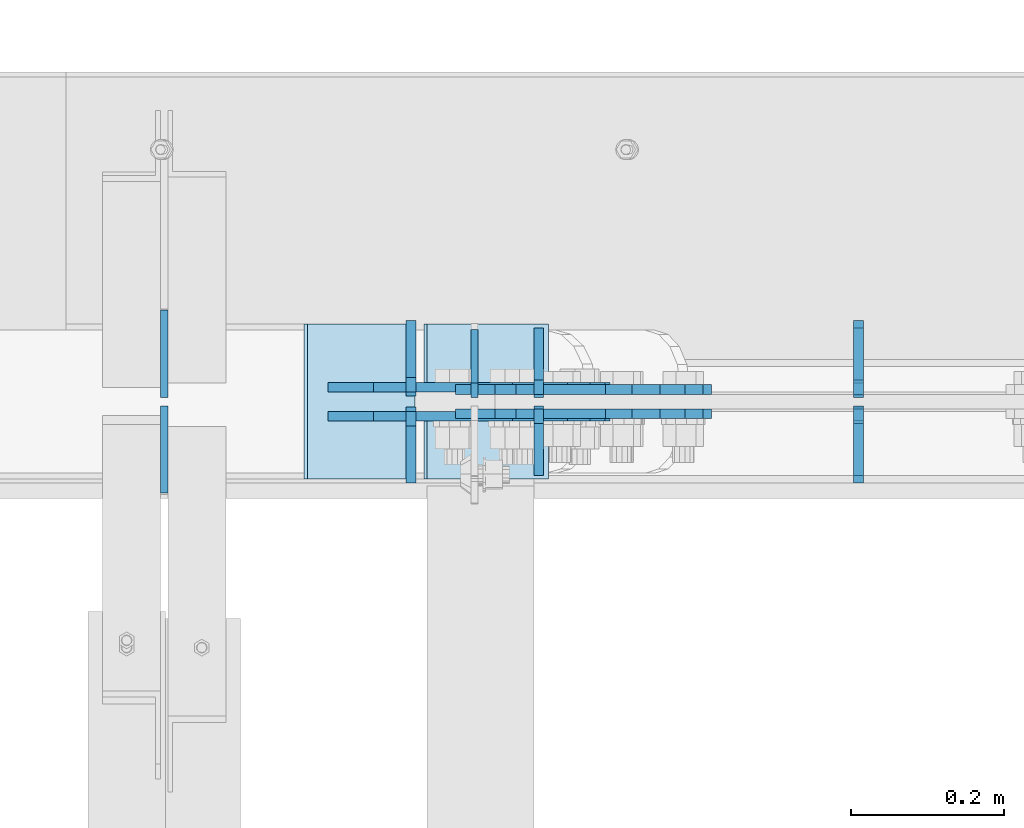
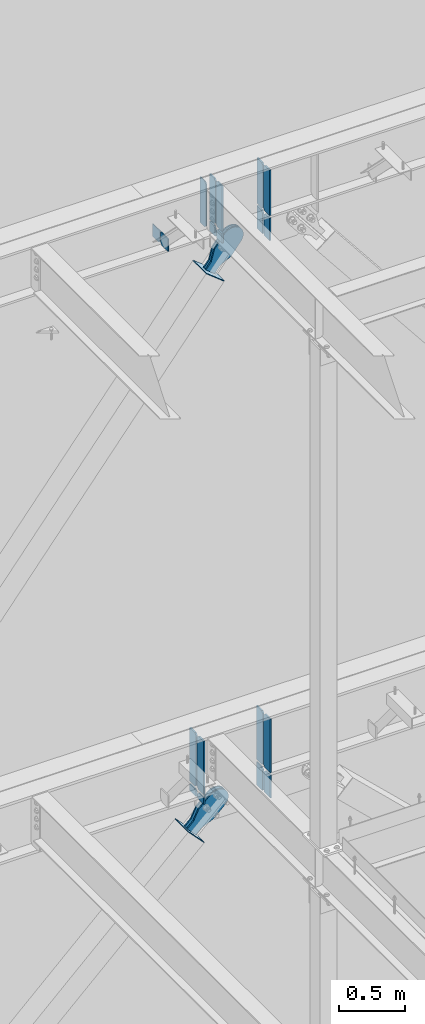
# One storey, part 1100 of 1179: 25 plates, 8 elements without a shape of their own.
"""IFC2X3 building model written with IfcOpenShell, lengths in millimetres."""

from ifc_helpers import new_model, si_unit, frame, origin_with_axes, place, context, subcontext, project, spatial, faceted_brep, material, type_object, element, aggregate, save


model = new_model("IFC2X3")

# Units and contexts
model_context = context("Model", 3, precision=1e-05, world=origin_with_axes())
body_context = subcontext(model_context, "Body", "Model", "MODEL_VIEW")
ifc_project = project(units=[si_unit("LENGTHUNIT", "METRE", prefix="MILLI"), si_unit("AREAUNIT", "SQUARE_METRE"), si_unit("VOLUMEUNIT", "CUBIC_METRE"), si_unit("MASSUNIT", "GRAM", prefix="KILO"), si_unit("TIMEUNIT", "SECOND"), si_unit("PLANEANGLEUNIT", "RADIAN"), si_unit("SOLIDANGLEUNIT", "STERADIAN"), si_unit("THERMODYNAMICTEMPERATUREUNIT", "DEGREE_CELSIUS"), si_unit("LUMINOUSINTENSITYUNIT", "LUMEN")], contexts=[model_context])

# Site, building, storey
site_placement = place(None, origin_with_axes())
site = spatial("IfcSite", under=ifc_project, at=site_placement, CompositionType="ELEMENT")
building_placement = place(site_placement, origin_with_axes())
building = spatial("IfcBuilding", under=site, at=building_placement, Name="Undefined", CompositionType="ELEMENT")
storey_placement = place(building_placement, origin_with_axes())
storey = spatial("IfcBuildingStorey", under=building, at=storey_placement, Name="Undefined", CompositionType="ELEMENT", Elevation=0.0)

# Assembly, plate
assembly_1_placement = place(storey_placement, origin_with_axes())
assembly_1 = element("IfcElementAssembly", 1, at=assembly_1_placement, inside=storey, Name="BEAM", AssemblyPlace="NOTDEFINED", PredefinedType="RIGID_FRAME")
ifc_material_1 = material(Name="STEEL/A36")
plate_type_1 = type_object("IfcPlateType", PredefinedType="NOTDEFINED")
plate_1_placement = place(assembly_1_placement, frame((11866.5620000839, 41204.35625, 12673.0125), z_axis=(0.0, 0.0, 1.0), x_axis=(0.0, 1.0, 0.0)))
plate_1 = element("IfcPlate", 2, at=plate_1_placement, type_object=plate_type_1, material=ifc_material_1, Name="PLATE", context=body_context, shape_type="Brep", body=[
    faceted_brep([(0.0, -4.76250000000073, 19.0499992370605), (0.0, -4.76249999999709, 406.400000762939), (0.0, 4.76249999999709, 406.400000762939), (0.0, 4.76250000000073, 19.0499992370605), (19.0499992370605, -4.76249999999709, 425.45), (19.0499992370605, 4.76249999999709, 425.45), (88.9000015258789, -4.76250000000073, 425.450012207031), (88.9000015258789, 4.76250000000073, 425.450012207031), (88.8999999999996, -4.76250000000005, 0.0), (88.8999999999996, 4.76250000000005, 0.0), (19.0499992370605, -4.76250000000073, 0.0), (19.0499992370605, 4.76250000000073, 0.0)], [[[0, 1, 2, 3]], [[1, 4, 5, 2]], [[4, 6, 7, 5]], [[6, 8, 9, 7]], [[8, 10, 11, 9]], [[10, 0, 3, 11]], [[5, 7, 9, 11, 3, 2]], [[10, 8, 6, 4, 1, 0]]]),
])

# Assembly, plates
assembly_2_placement = place(storey_placement, origin_with_axes())
assembly_2 = element("IfcElementAssembly", 3, at=assembly_2_placement, inside=storey, Name="BEAM", AssemblyPlace="NOTDEFINED", PredefinedType="RIGID_FRAME")
ifc_material_2 = material(Name="STEEL/A572-GR.50")
plate_type_2 = type_object("IfcPlateType", PredefinedType="NOTDEFINED")
plate_2_placement = place(assembly_2_placement, frame((12369.8, 41205.94375, 7488.2375), z_axis=(0.0, 1.0, 0.0), x_axis=(0.0, 0.0, 1.0)))
plate_2 = element("IfcPlate", 4, at=plate_2_placement, type_object=plate_type_2, material=ifc_material_2, Name="PLATE", context=body_context, shape_type="Brep", body=[
    faceted_brep([(0.0, -6.34999999998763, 17.4624996185248), (0.0, -6.35000000000036, 99.21875), (0.0, 6.35000000000036, 99.21875), (0.0, 6.35000000000582, 17.4624996185175), (501.65, -6.35000000000036, 99.21875), (501.65, 6.35000000000036, 99.21875), (501.65, -6.35000000000036, 17.4624996185303), (501.65, 6.35000000000036, 17.4624996185303), (484.187500381469, -6.35000000000036, 0.0), (484.187500381469, 6.35000000000036, 0.0), (17.4624996185303, -6.34999999999309, 1.81898940354586e-12), (17.4624996185303, 6.34999999999854, -1.81898940354586e-12)], [[[0, 1, 2, 3]], [[1, 4, 5, 2]], [[4, 6, 7, 5]], [[6, 8, 9, 7]], [[8, 10, 11, 9]], [[10, 0, 3, 11]], [[5, 7, 9, 11, 3, 2]], [[10, 8, 6, 4, 1, 0]]]),
])
plate_3_placement = place(assembly_2_placement, frame((12369.8, 41191.65625, 7488.2375), z_axis=(0.0, -1.0, 0.0), x_axis=(0.0, 0.0, 1.0)))
plate_3 = element("IfcPlate", 5, at=plate_3_placement, type_object=plate_type_2, material=ifc_material_2, Name="PLATE", context=body_context, shape_type="Brep", body=[
    faceted_brep([(0.0, -6.34999999998763, 17.4624996185248), (0.0, -6.35000000000036, 99.21875), (0.0, 6.35000000000036, 99.21875), (0.0, 6.35000000000582, 17.4624996185175), (501.65, -6.35000000000036, 99.21875), (501.65, 6.35000000000036, 99.21875), (501.65, -6.35000000000036, 17.4624996185303), (501.65, 6.35000000000036, 17.4624996185303), (484.187500381469, -6.35000000000036, 0.0), (484.187500381469, 6.35000000000036, 0.0), (17.4624996185303, -6.34999999999309, 1.81898940354586e-12), (17.4624996185303, 6.34999999999854, -1.81898940354586e-12)], [[[0, 1, 2, 3]], [[1, 4, 5, 2]], [[4, 6, 7, 5]], [[6, 8, 9, 7]], [[8, 10, 11, 9]], [[10, 0, 3, 11]], [[5, 7, 9, 11, 3, 2]], [[10, 8, 6, 4, 1, 0]]]),
])
plate_4_placement = place(assembly_2_placement, frame((11783.4171875, 41205.94375, 7489.825), z_axis=(0.0, 1.0, 0.0), x_axis=(0.0, 0.0, 1.0)))
plate_4 = element("IfcPlate", 6, at=plate_4_placement, type_object=plate_type_2, material=ifc_material_2, Name="PLATE", context=body_context, shape_type="Brep", body=[
    faceted_brep([(0.0, -6.35000000000036, 19.0499999999993), (0.0, -6.35000000000036, 99.21875), (0.0, 6.35000000000036, 99.21875), (0.0, 6.35000000000036, 19.0499999999993), (498.475, -6.35000000000036, 99.21875), (498.475, 6.35000000000036, 99.21875), (498.475006103516, -6.35000000000036, 19.0499992370605), (498.475006103516, 6.35000000000036, 19.0499992370605), (479.425006866455, -6.35000000000036, 0.0), (479.425006866455, 6.35000000000036, 0.0), (19.0500000000002, -6.35000000000036, 0.0), (19.0500000000002, 6.35000000000036, 0.0)], [[[0, 1, 2, 3]], [[1, 4, 5, 2]], [[4, 6, 7, 5]], [[6, 8, 9, 7]], [[8, 10, 11, 9]], [[3, 11, 10, 0]], [[5, 7, 9, 11, 3, 2]], [[10, 8, 6, 4, 1, 0]]]),
])
plate_5_placement = place(assembly_2_placement, frame((11783.4171875, 41191.65625, 7489.825), z_axis=(0.0, -1.0, 0.0), x_axis=(0.0, 0.0, 1.0)))
plate_5 = element("IfcPlate", 7, at=plate_5_placement, type_object=plate_type_2, material=ifc_material_2, Name="PLATE", context=body_context, shape_type="Brep", body=[
    faceted_brep([(0.0, -6.35000000000036, 19.0499999999993), (0.0, -6.35000000000036, 99.21875), (0.0, 6.35000000000036, 99.21875), (0.0, 6.35000000000036, 19.0499999999993), (498.475, -6.35000000000036, 99.21875), (498.475, 6.35000000000036, 99.21875), (498.475006103516, -6.35000000000036, 19.0499992370605), (498.475006103516, 6.35000000000036, 19.0499992370605), (479.425006866455, -6.35000000000036, 0.0), (479.425006866455, 6.35000000000036, 0.0), (19.0500000000002, -6.35000000000036, 0.0), (19.0500000000002, 6.35000000000036, 0.0)], [[[0, 1, 2, 3]], [[1, 4, 5, 2]], [[4, 6, 7, 5]], [[6, 8, 9, 7]], [[8, 10, 11, 9]], [[3, 11, 10, 0]], [[5, 7, 9, 11, 3, 2]], [[10, 8, 6, 4, 1, 0]]]),
])

# Assembly, plate
assembly_3_placement = place(storey_placement, origin_with_axes())
assembly_3 = element("IfcElementAssembly", 8, at=assembly_3_placement, inside=storey, Name="Plate", AssemblyPlace="NOTDEFINED", PredefinedType="RIGID_FRAME")
plate_type_3 = type_object("IfcPlateType", PredefinedType="NOTDEFINED")
plate_6_placement = place(assembly_3_placement, frame((11961.3934668224, 41097.2, 12208.4235733512), z_axis=(-0.782937860640372, 0.0, 0.62209991671425), x_axis=(0.0, 1.0, 0.0)))
plate_6 = element("IfcPlate", 9, at=plate_6_placement, type_object=plate_type_3, material=ifc_material_1, Name="Plate", context=body_context, shape_type="Brep", body=[
    faceted_brep([(0.0, -3.17500000000109, 0.0), (0.0, -3.17500000000291, 203.200000000368), (0.0, 3.17499999998836, 203.200000000361), (0.0, 3.17500000000109, 7.27595761418343e-12), (203.199999999997, -3.17500000000291, 203.200000000368), (203.199999999997, 3.17499999998836, 203.200000000361), (203.199999999997, -3.17499999999927, 3.63797880709171e-12), (203.199999999997, 3.17499999999382, -3.63797880709171e-12)], [[[0, 1, 2, 3]], [[1, 4, 5, 2]], [[4, 6, 7, 5]], [[6, 0, 3, 7]], [[5, 7, 3, 2]], [[6, 4, 1, 0]]]),
])
aggregate(assembly_3, [plate_6])

assembly_4_placement = place(storey_placement, origin_with_axes())
assembly_4 = element("IfcElementAssembly", 10, at=assembly_4_placement, inside=storey, Name="Plate", AssemblyPlace="NOTDEFINED", PredefinedType="RIGID_FRAME")
plate_7_placement = place(assembly_4_placement, frame((11786.1245523954, 41097.2, 7040.16901299028), z_axis=(-0.691222646058185, 0.0, 0.722641857060828), x_axis=(0.0, 1.0, 0.0)))
plate_7 = element("IfcPlate", 11, at=plate_7_placement, type_object=plate_type_3, material=ifc_material_1, Name="Plate", context=body_context, shape_type="Brep", body=[
    faceted_brep([(0.0, -3.17500000000109, 0.0), (0.0, -3.17500000000291, 203.200000000368), (0.0, 3.17499999998836, 203.200000000361), (0.0, 3.17500000000109, 7.27595761418343e-12), (203.199999999997, -3.17500000000291, 203.200000000368), (203.199999999997, 3.17499999998836, 203.200000000361), (203.199999999997, -3.17499999999927, 3.63797880709171e-12), (203.199999999997, 3.17499999999382, -3.63797880709171e-12)], [[[0, 1, 2, 3]], [[1, 4, 5, 2]], [[4, 6, 7, 5]], [[6, 0, 3, 7]], [[5, 7, 3, 2]], [[6, 4, 1, 0]]]),
])
aggregate(assembly_4, [plate_7])

# Plate
plate_type_4 = type_object("IfcPlateType", PredefinedType="NOTDEFINED")
plate_8_placement = place(assembly_1_placement, frame((12369.7999987844, 41204.35625, 12673.0125), z_axis=(0.0, 1.0, 0.0), x_axis=(0.0, 0.0, 1.0)))
plate_8 = element("IfcPlate", 12, at=plate_8_placement, type_object=plate_type_4, material=ifc_material_2, Name="PLATE", context=body_context, shape_type="Brep", body=[
    faceted_brep([(0.0, -6.34999999998763, 17.4624996185248), (0.0, -6.35000000000036, 91.28125), (0.0, 6.35000000000036, 91.28125), (0.0, 6.35000000000582, 17.4624996185175), (425.450000000001, -6.35000000000036, 91.28125), (425.450000000001, 6.35000000000036, 91.28125), (425.450000000001, -6.35000000000036, 17.4624996185303), (425.450000000001, 6.35000000000036, 17.4624996185303), (407.98750038147, -6.35000000000036, 0.0), (407.98750038147, 6.35000000000036, 0.0), (17.4624996185303, -6.34999999999309, 1.81898940354586e-12), (17.4624996185303, 6.34999999999854, -1.81898940354586e-12)], [[[0, 1, 2, 3]], [[1, 4, 5, 2]], [[4, 6, 7, 5]], [[6, 8, 9, 7]], [[8, 10, 11, 9]], [[10, 0, 3, 11]], [[5, 7, 9, 11, 3, 2]], [[10, 8, 6, 4, 1, 0]]]),
])

plate_9_placement = place(assembly_1_placement, frame((12369.7999987844, 41193.24375, 12673.0125), z_axis=(0.0, -1.0, 0.0), x_axis=(0.0, 0.0, 1.0)))
plate_9 = element("IfcPlate", 13, at=plate_9_placement, type_object=plate_type_4, material=ifc_material_2, Name="PLATE", context=body_context, shape_type="Brep", body=[
    faceted_brep([(0.0, -6.34999999998763, 17.4624996185248), (0.0, -6.35000000000036, 91.28125), (0.0, 6.35000000000036, 91.28125), (0.0, 6.35000000000582, 17.4624996185175), (425.450000000001, -6.35000000000036, 91.28125), (425.450000000001, 6.35000000000036, 91.28125), (425.450000000001, -6.35000000000036, 17.4624996185303), (425.450000000001, 6.35000000000036, 17.4624996185303), (407.98750038147, -6.35000000000036, 0.0), (407.98750038147, 6.35000000000036, 0.0), (17.4624996185303, -6.34999999999309, 1.81898940354586e-12), (17.4624996185303, 6.34999999999854, -1.81898940354586e-12)], [[[0, 1, 2, 3]], [[1, 4, 5, 2]], [[4, 6, 7, 5]], [[6, 8, 9, 7]], [[8, 10, 11, 9]], [[10, 0, 3, 11]], [[5, 7, 9, 11, 3, 2]], [[10, 8, 6, 4, 1, 0]]]),
])

plate_type_5 = type_object("IfcPlateType", PredefinedType="NOTDEFINED")
plate_10_placement = place(assembly_1_placement, frame((11950.7, 41208.325, 12652.375), z_axis=(0.0, 1.0, 0.0), x_axis=(0.0, 0.0, -1.0)))
plate_10 = element("IfcPlate", 14, at=plate_10_placement, type_object=plate_type_5, material=ifc_material_2, Name="PLATE", context=body_context, shape_type="Brep", body=[
    faceted_brep([(0.0, 6.35000000000036, 19.0499999999993), (19.0500000000002, 6.35000000000036, 0.0), (19.0500000000002, -6.35000000000036, 0.0), (0.0, -6.35000000000036, 19.0499999999993), (0.0, -6.35000000000036, 87.3125), (0.0, 6.35000000000036, 87.3125), (88.7851254133348, -6.35000000000036, 87.3125), (88.7851254133348, 6.35000000000036, 87.3125), (88.7851254133348, -6.35000000000036, 0.0), (88.7851254133348, 6.35000000000036, 0.0)], [[[0, 1, 2, 3]], [[4, 5, 0, 3]], [[4, 6, 7, 5]], [[6, 8, 9, 7]], [[9, 8, 2, 1]], [[5, 7, 9, 1, 0]], [[8, 6, 4, 3, 2]]]),
])

plate_11_placement = place(assembly_1_placement, frame((11950.7, 41189.275, 12652.375), z_axis=(0.0, -1.0, 0.0), x_axis=(0.0, 0.0, -1.0)))
plate_11 = element("IfcPlate", 15, at=plate_11_placement, type_object=plate_type_5, material=ifc_material_2, Name="PLATE", context=body_context, shape_type="Brep", body=[
    faceted_brep([(0.0, 6.35000000000036, 19.0499999999993), (19.0500000000002, 6.35000000000036, 0.0), (19.0500000000002, -6.35000000000036, 0.0), (0.0, -6.35000000000036, 19.0499999999993), (0.0, -6.35000000000036, 87.3125), (0.0, 6.35000000000036, 87.3125), (88.7851254133348, -6.35000000000036, 87.3125), (88.7851254133348, 6.35000000000036, 87.3125), (88.7851254133348, -6.35000000000036, 0.0), (88.7851254133348, 6.35000000000036, 0.0)], [[[0, 1, 2, 3]], [[4, 5, 0, 3]], [[4, 6, 7, 5]], [[6, 8, 9, 7]], [[9, 8, 2, 1]], [[5, 7, 9, 1, 0]], [[8, 6, 4, 3, 2]]]),
])

plate_12_placement = place(assembly_1_placement, frame((12369.8, 41208.325, 12440.8523319191), z_axis=(0.0, 1.0, 0.0), x_axis=(0.0, 0.0, 1.0)))
plate_12 = element("IfcPlate", 16, at=plate_12_placement, type_object=plate_type_5, material=ifc_material_2, Name="PLATE", context=body_context, shape_type="Brep", body=[
    faceted_brep([(211.522668080917, -6.35000000000036, 19.0500000000029), (192.472668080918, -6.35000000000036, 0.0), (192.472668080918, 6.35000000000036, 0.0), (211.522668080917, 6.35000000000036, 19.0500000000029), (0.0, -6.34999999999854, 0.0), (0.0, -6.35000000000036, 87.3125), (0.0, 6.35000000000036, 87.3125), (0.0, 6.34999999999854, 0.0), (211.522668080917, -6.35000000000036, 87.3125), (211.522668080917, 6.35000000000036, 87.3125)], [[[0, 1, 2, 3]], [[4, 5, 6, 7]], [[5, 8, 9, 6]], [[9, 8, 0, 3]], [[4, 7, 2, 1]], [[7, 6, 9, 3, 2]], [[8, 5, 4, 1, 0]]]),
])

plate_13_placement = place(assembly_1_placement, frame((12369.8, 41189.275, 12440.8523319191), z_axis=(0.0, -1.0, 0.0), x_axis=(0.0, 0.0, 1.0)))
plate_13 = element("IfcPlate", 17, at=plate_13_placement, type_object=plate_type_5, material=ifc_material_2, Name="PLATE", context=body_context, shape_type="Brep", body=[
    faceted_brep([(211.522668080917, -6.35000000000036, 19.0500000000029), (192.472668080918, -6.35000000000036, 0.0), (192.472668080918, 6.35000000000036, 0.0), (211.522668080917, 6.35000000000036, 19.0500000000029), (0.0, -6.34999999999854, 0.0), (0.0, -6.35000000000036, 87.3125), (0.0, 6.35000000000036, 87.3125), (0.0, 6.34999999999854, 0.0), (211.522668080917, -6.35000000000036, 87.3125), (211.522668080917, 6.35000000000036, 87.3125)], [[[0, 1, 2, 3]], [[4, 5, 6, 7]], [[5, 8, 9, 6]], [[9, 8, 0, 3]], [[4, 7, 2, 1]], [[7, 6, 9, 3, 2]], [[8, 5, 4, 1, 0]]]),
])

plate_type_6 = type_object("IfcPlateType", PredefinedType="NOTDEFINED")
plate_14_placement = place(assembly_1_placement, frame((11950.7, 41104.34375, 12673.0125), z_axis=(0.0, 0.0, 1.0), x_axis=(0.0, 1.0, 0.0)))
plate_14 = element("IfcPlate", 18, at=plate_14_placement, type_object=plate_type_6, material=ifc_material_2, Name="PLATE", context=body_context, shape_type="Brep", body=[
    faceted_brep([(0.0, -6.34999999999854, 0.0), (0.0, -6.34999999999991, 425.450012207031), (0.0, 6.34999999999991, 425.450012207031), (0.0, 6.34999999999854, 0.0), (69.8500022888184, -6.34999999999991, 425.450012207031), (69.8500022888184, 6.34999999999991, 425.450012207031), (88.9000015258789, -6.34999999999991, 406.400012969971), (88.9000015258789, 6.34999999999991, 406.400012969971), (88.9000015258789, -6.34999999999991, 19.0499992370605), (88.9000015258789, 6.34999999999991, 19.0499992370605), (69.849999425729, -6.34999999999854, 0.0), (69.849999425729, 6.34999999999854, 0.0)], [[[0, 1, 2, 3]], [[1, 4, 5, 2]], [[4, 6, 7, 5]], [[6, 8, 9, 7]], [[8, 10, 11, 9]], [[10, 0, 3, 11]], [[5, 7, 9, 11, 3, 2]], [[10, 8, 6, 4, 1, 0]]]),
])

plate_15_placement = place(assembly_1_placement, frame((11950.7, 41204.35625, 12673.0125), z_axis=(0.0, 0.0, 1.0), x_axis=(0.0, 1.0, 0.0)))
plate_15 = element("IfcPlate", 19, at=plate_15_placement, type_object=plate_type_6, material=ifc_material_2, Name="PLATE", context=body_context, shape_type="Brep", body=[
    faceted_brep([(0.0, -6.35000000000036, 19.0499999999993), (0.0, -6.34999999999991, 406.400012969971), (0.0, 6.34999999999991, 406.400012969971), (0.0, 6.35000000000036, 19.0499999999993), (19.0499992370605, -6.34999999999991, 425.450012207031), (19.0499992370605, 6.34999999999991, 425.450012207031), (88.9000015258789, -6.34999999999991, 425.450012207031), (88.9000015258789, 6.34999999999991, 425.450012207031), (88.9000015258789, -6.34999999999991, 0.0), (88.9000015258789, 6.34999999999991, 0.0), (19.0500000000002, -6.35000000000036, 0.0), (19.0500000000002, 6.35000000000036, 0.0)], [[[0, 1, 2, 3]], [[1, 4, 5, 2]], [[4, 6, 7, 5]], [[6, 8, 9, 7]], [[8, 10, 11, 9]], [[3, 11, 10, 0]], [[5, 7, 9, 11, 3, 2]], [[10, 8, 6, 4, 1, 0]]]),
])

plate_type_7 = type_object("IfcPlateType", PredefinedType="NOTDEFINED")
plate_16_placement = place(assembly_2_placement, frame((11783.4171875, 41211.5, 7464.42500002202), z_axis=(0.0, 1.0, 0.0), x_axis=(0.0, 0.0, -1.0)))
plate_16 = element("IfcPlate", 20, at=plate_16_placement, type_object=plate_type_7, material=ifc_material_2, Name="PLATE", context=body_context, shape_type="Brep", body=[
    faceted_brep([(0.0, 6.35000000000036, 19.0499999999993), (19.0500000000002, 6.35000000000036, 0.0), (19.0500000000002, -6.35000000000036, 0.0), (0.0, -6.35000000000036, 19.0499999999993), (0.0, -6.35000000000036, 93.6625000000058), (0.0, 6.35000000000036, 93.6625000000058), (63.5020087381745, -6.35000000000036, 93.6625000000058), (63.5020087381745, 6.35000000000036, 93.6625000000058), (63.5020087381745, -6.35000000000036, 0.0), (63.5020087381745, 6.35000000000036, 0.0)], [[[0, 1, 2, 3]], [[4, 5, 0, 3]], [[4, 6, 7, 5]], [[6, 8, 9, 7]], [[9, 8, 2, 1]], [[5, 7, 9, 1, 0]], [[8, 6, 4, 3, 2]]]),
])

plate_17_placement = place(assembly_2_placement, frame((11783.4171875, 41186.1, 7464.42500002202), z_axis=(0.0, -1.0, 0.0), x_axis=(0.0, 0.0, -1.0)))
plate_17 = element("IfcPlate", 21, at=plate_17_placement, type_object=plate_type_7, material=ifc_material_2, Name="PLATE", context=body_context, shape_type="Brep", body=[
    faceted_brep([(0.0, 6.35000000000036, 19.0499999999993), (19.0500000000002, 6.35000000000036, 0.0), (19.0500000000002, -6.35000000000036, 0.0), (0.0, -6.35000000000036, 19.0499999999993), (0.0, -6.35000000000036, 93.6625000000058), (0.0, 6.35000000000036, 93.6625000000058), (63.5020087381745, -6.35000000000036, 93.6625000000058), (63.5020087381745, 6.35000000000036, 93.6625000000058), (63.5020087381745, -6.35000000000036, 0.0), (63.5020087381745, 6.35000000000036, 0.0)], [[[0, 1, 2, 3]], [[4, 5, 0, 3]], [[4, 6, 7, 5]], [[6, 8, 9, 7]], [[9, 8, 2, 1]], [[5, 7, 9, 1, 0]], [[8, 6, 4, 3, 2]]]),
])

plate_type_8 = type_object("IfcPlateType", PredefinedType="NOTDEFINED")
plate_18_placement = place(assembly_2_placement, frame((12369.8, 41211.5, 7464.425), z_axis=(0.0, 1.0, 0.0), x_axis=(0.0, 0.0, -1.0)))
plate_18 = element("IfcPlate", 22, at=plate_18_placement, type_object=plate_type_8, material=ifc_material_2, Name="PLATE", context=body_context, shape_type="Brep", body=[
    faceted_brep([(0.0, 6.35000000000036, 19.0499999999993), (19.0500000000002, 6.35000000000036, 0.0), (19.0500000000002, -6.35000000000036, 0.0), (0.0, -6.35000000000036, 19.0499999999993), (0.0, -6.35000000000036, 93.6625000000058), (0.0, 6.35000000000036, 93.6625000000058), (210.181102062119, -6.35000000000036, 93.6625000000058), (210.181102062119, 6.35000000000036, 93.6625000000058), (210.181102062119, -6.35000000000036, 0.0), (210.181102062119, 6.35000000000036, 0.0)], [[[0, 1, 2, 3]], [[4, 5, 0, 3]], [[4, 6, 7, 5]], [[6, 8, 9, 7]], [[9, 8, 2, 1]], [[5, 7, 9, 1, 0]], [[8, 6, 4, 3, 2]]]),
])

plate_19_placement = place(assembly_2_placement, frame((12369.8, 41186.1, 7464.425), z_axis=(0.0, -1.0, 0.0), x_axis=(0.0, 0.0, -1.0)))
plate_19 = element("IfcPlate", 23, at=plate_19_placement, type_object=plate_type_8, material=ifc_material_2, Name="PLATE", context=body_context, shape_type="Brep", body=[
    faceted_brep([(0.0, 6.35000000000036, 19.0499999999993), (19.0500000000002, 6.35000000000036, 0.0), (19.0500000000002, -6.35000000000036, 0.0), (0.0, -6.35000000000036, 19.0499999999993), (0.0, -6.35000000000036, 93.6625000000058), (0.0, 6.35000000000036, 93.6625000000058), (210.181102062119, -6.35000000000036, 93.6625000000058), (210.181102062119, 6.35000000000036, 93.6625000000058), (210.181102062119, -6.35000000000036, 0.0), (210.181102062119, 6.35000000000036, 0.0)], [[[0, 1, 2, 3]], [[4, 5, 0, 3]], [[4, 6, 7, 5]], [[6, 8, 9, 7]], [[9, 8, 2, 1]], [[5, 7, 9, 1, 0]], [[8, 6, 4, 3, 2]]]),
])

aggregate(assembly_2, [plate_2, plate_3, plate_16, plate_17, plate_4, plate_5, plate_18, plate_19])

# Assembly, plate
assembly_5_placement = place(storey_placement, origin_with_axes())
assembly_5 = element("IfcElementAssembly", 24, at=assembly_5_placement, inside=storey, AssemblyPlace="NOTDEFINED", PredefinedType="RIGID_FRAME")
plate_type_9 = type_object("IfcPlateType", PredefinedType="NOTDEFINED")
plate_20_placement = place(assembly_5_placement, frame((11917.9044352925, 41214.675, 12238.9234688004), z_axis=(-0.782937860640372, 0.0, 0.62209991671425), x_axis=(0.622099916714251, 0.0, 0.782937860640372)))
plate_20 = element("IfcPlate", 25, at=plate_20_placement, type_object=plate_type_9, material=ifc_material_1, context=body_context, shape_type="Brep", body=[
    faceted_brep([(0.0, -6.34999999999854, 0.0), (4.938556230627e-10, -6.34999999999854, 97.1536165479993), (4.938556230627e-10, 6.34999999999854, 97.1536165479993), (0.0, 6.34999999999854, 0.0), (82.5500000003167, -6.34999999999854, 97.1536165479301), (82.5500000003167, 6.34999999999854, 97.1536165479301), (184.150000000318, -6.34999999999854, 142.239308273958), (184.150000000318, 6.34999999999854, 142.239308273958), (327.919242322826, -6.34999999999854, 142.239308273831), (327.919242322826, 6.34999999999854, 142.239308273831), (363.762328722879, -6.34999999999854, 135.109675103751), (363.762328722879, 6.34999999999854, 135.109675103751), (394.148630136872, -6.34999999999854, 114.806197613441), (394.148630136872, 6.34999999999854, 114.806197613441), (414.452107627006, -6.34999999999854, 84.4198961993279), (414.452107627006, 6.34999999999854, 84.4198961993279), (421.581740796876, -6.34999999999854, 48.5768067472527), (421.581740796876, 6.34999999999854, 48.5768067472527), (414.452107626721, -6.34999999999854, 12.7337203474126), (414.452107626721, 6.34999999999854, 12.7337203474126), (394.148630136483, -6.34999999999854, -17.6525810663916), (394.148630136483, 6.34999999999854, -17.6525810663916), (363.762328722555, -6.34999999999854, -37.9560585564504), (363.762328722555, 6.34999999999854, -37.9560585564504), (327.9192407966, -6.34999999999854, -45.0856917263918), (327.9192407966, 6.34999999999854, -45.0856917263918), (184.149999999361, -6.34999999999854, -45.0856917262681), (184.149999999361, 6.34999999999854, -45.0856917262681), (82.550000000203, -6.34999999999854, 1.2732925824821e-10), (82.550000000203, 6.34999999999854, 1.2732925824821e-10)], [[[0, 1, 2, 3]], [[1, 4, 5, 2]], [[4, 6, 7, 5]], [[6, 8, 9, 7]], [[8, 10, 11, 9]], [[10, 12, 13, 11]], [[12, 14, 15, 13]], [[14, 16, 17, 15]], [[16, 18, 19, 17]], [[18, 20, 21, 19]], [[20, 22, 23, 21]], [[22, 24, 25, 23]], [[24, 26, 27, 25]], [[26, 28, 29, 27]], [[28, 0, 3, 29]], [[5, 7, 9, 11, 13, 15, 17, 19, 21, 23, 25, 27, 29, 3, 2]], [[28, 26, 24, 22, 20, 18, 16, 14, 12, 10, 8, 6, 4, 1, 0]]]),
])
aggregate(assembly_5, [plate_20])

assembly_6_placement = place(storey_placement, origin_with_axes())
assembly_6 = element("IfcElementAssembly", 26, at=assembly_6_placement, inside=storey, AssemblyPlace="NOTDEFINED", PredefinedType="RIGID_FRAME")
plate_21_placement = place(assembly_6_placement, frame((11917.9044352925, 41182.925, 12238.9234688004), z_axis=(-0.782937860640372, 0.0, 0.62209991671425), x_axis=(0.622099916714251, 0.0, 0.782937860640372)))
plate_21 = element("IfcPlate", 27, at=plate_21_placement, type_object=plate_type_9, material=ifc_material_1, context=body_context, shape_type="Brep", body=[
    faceted_brep([(0.0, -6.34999999999854, 0.0), (4.938556230627e-10, -6.34999999999854, 97.1536165479993), (4.938556230627e-10, 6.34999999999854, 97.1536165479993), (0.0, 6.34999999999854, 0.0), (82.5500000003167, -6.34999999999854, 97.1536165479301), (82.5500000003167, 6.34999999999854, 97.1536165479301), (184.150000000318, -6.34999999999854, 142.239308273958), (184.150000000318, 6.34999999999854, 142.239308273958), (327.919242322826, -6.34999999999854, 142.239308273831), (327.919242322826, 6.34999999999854, 142.239308273831), (363.762328722879, -6.34999999999854, 135.109675103751), (363.762328722879, 6.34999999999854, 135.109675103751), (394.148630136872, -6.34999999999854, 114.806197613441), (394.148630136872, 6.34999999999854, 114.806197613441), (414.452107627006, -6.34999999999854, 84.4198961993279), (414.452107627006, 6.34999999999854, 84.4198961993279), (421.581740796876, -6.34999999999854, 48.5768067472527), (421.581740796876, 6.34999999999854, 48.5768067472527), (414.452107626721, -6.34999999999854, 12.7337203474126), (414.452107626721, 6.34999999999854, 12.7337203474126), (394.148630136483, -6.34999999999854, -17.6525810663916), (394.148630136483, 6.34999999999854, -17.6525810663916), (363.762328722555, -6.34999999999854, -37.9560585564504), (363.762328722555, 6.34999999999854, -37.9560585564504), (327.9192407966, -6.34999999999854, -45.0856917263918), (327.9192407966, 6.34999999999854, -45.0856917263918), (184.149999999361, -6.34999999999854, -45.0856917262681), (184.149999999361, 6.34999999999854, -45.0856917262681), (82.550000000203, -6.34999999999854, 1.2732925824821e-10), (82.550000000203, 6.34999999999854, 1.2732925824821e-10)], [[[0, 1, 2, 3]], [[1, 4, 5, 2]], [[4, 6, 7, 5]], [[6, 8, 9, 7]], [[8, 10, 11, 9]], [[10, 12, 13, 11]], [[12, 14, 15, 13]], [[14, 16, 17, 15]], [[16, 18, 19, 17]], [[18, 20, 21, 19]], [[20, 22, 23, 21]], [[22, 24, 25, 23]], [[24, 26, 27, 25]], [[26, 28, 29, 27]], [[28, 0, 3, 29]], [[5, 7, 9, 11, 13, 15, 17, 19, 21, 23, 25, 27, 29, 3, 2]], [[28, 26, 24, 22, 20, 18, 16, 14, 12, 10, 8, 6, 4, 1, 0]]]),
])
aggregate(assembly_6, [plate_21])

assembly_7_placement = place(storey_placement, origin_with_axes())
assembly_7 = element("IfcElementAssembly", 28, at=assembly_7_placement, inside=storey, AssemblyPlace="NOTDEFINED", PredefinedType="RIGID_FRAME")
plate_22_placement = place(assembly_7_placement, frame((11752.3743260204, 41217.85, 7070.86003039913), z_axis=(-0.691222646058185, 0.0, 0.722641857060828), x_axis=(0.722641857060828, 0.0, 0.691222646058184)))
plate_22 = element("IfcPlate", 29, at=plate_22_placement, type_object=plate_type_9, material=ifc_material_1, context=body_context, shape_type="Brep", body=[
    faceted_brep([(0.0, -6.34999999999854, 0.0), (-4.35647962149233e-10, -6.34999999999854, 112.184930806416), (-4.35647962149233e-10, 6.34999999999854, 112.184930806416), (0.0, 6.34999999999854, 0.0), (82.5499999996491, -6.34999999999854, 112.184930806461), (82.5499999996491, 6.34999999999854, 112.184930806461), (184.149999999618, -6.34999999999854, 149.75496540347), (184.149999999618, 6.34999999999854, 149.75496540347), (327.919242323534, -6.34999999999854, 149.754965403559), (327.919242323534, 6.34999999999854, 149.754965403559), (363.762328723451, -6.34999999999854, 142.625332233587), (363.762328723451, 6.34999999999854, 142.625332233587), (394.148630137406, -6.34999999999854, 122.321854743475), (394.148630137406, 6.34999999999854, 122.321854743475), (414.452107627645, -6.34999999999854, 91.9355533295929), (414.452107627645, 6.34999999999854, 91.9355533295929), (421.581740797776, -6.34999999999854, 56.0924638777396), (421.581740797776, 6.34999999999854, 56.0924638777396), (414.452107627878, -6.34999999999854, 20.2493774776722), (414.452107627878, 6.34999999999854, 20.2493774776722), (394.14863013775, -6.34999999999854, -10.1369239363994), (394.14863013775, 6.34999999999854, -10.1369239363994), (363.762328723789, -6.34999999999854, -30.4404014266784), (363.762328723789, 6.34999999999854, -30.4404014266784), (327.919240798041, -6.34999999999854, -37.570034596738), (327.919240798041, 6.34999999999854, -37.570034596738), (184.150000000338, -6.34999999999854, -37.5700345968289), (184.150000000338, 6.34999999999854, -37.5700345968289), (82.550000000203, -6.34999999999854, 1.2732925824821e-10), (82.550000000203, 6.34999999999854, 1.2732925824821e-10)], [[[0, 1, 2, 3]], [[1, 4, 5, 2]], [[4, 6, 7, 5]], [[6, 8, 9, 7]], [[8, 10, 11, 9]], [[10, 12, 13, 11]], [[12, 14, 15, 13]], [[14, 16, 17, 15]], [[16, 18, 19, 17]], [[18, 20, 21, 19]], [[20, 22, 23, 21]], [[22, 24, 25, 23]], [[24, 26, 27, 25]], [[26, 28, 29, 27]], [[28, 0, 3, 29]], [[5, 7, 9, 11, 13, 15, 17, 19, 21, 23, 25, 27, 29, 3, 2]], [[28, 26, 24, 22, 20, 18, 16, 14, 12, 10, 8, 6, 4, 1, 0]]]),
])
aggregate(assembly_7, [plate_22])

assembly_8_placement = place(storey_placement, origin_with_axes())
assembly_8 = element("IfcElementAssembly", 30, at=assembly_8_placement, inside=storey, AssemblyPlace="NOTDEFINED", PredefinedType="RIGID_FRAME")
plate_23_placement = place(assembly_8_placement, frame((11752.3743260204, 41179.75, 7070.86003039913), z_axis=(-0.691222646058185, 0.0, 0.722641857060828), x_axis=(0.722641857060828, 0.0, 0.691222646058184)))
plate_23 = element("IfcPlate", 31, at=plate_23_placement, type_object=plate_type_9, material=ifc_material_1, context=body_context, shape_type="Brep", body=[
    faceted_brep([(0.0, -6.34999999999854, 0.0), (-4.35647962149233e-10, -6.34999999999854, 112.184930806416), (-4.35647962149233e-10, 6.34999999999854, 112.184930806416), (0.0, 6.34999999999854, 0.0), (82.5499999996491, -6.34999999999854, 112.184930806461), (82.5499999996491, 6.34999999999854, 112.184930806461), (184.149999999618, -6.34999999999854, 149.75496540347), (184.149999999618, 6.34999999999854, 149.75496540347), (327.919242323534, -6.34999999999854, 149.754965403559), (327.919242323534, 6.34999999999854, 149.754965403559), (363.762328723451, -6.34999999999854, 142.625332233587), (363.762328723451, 6.34999999999854, 142.625332233587), (394.148630137406, -6.34999999999854, 122.321854743475), (394.148630137406, 6.34999999999854, 122.321854743475), (414.452107627645, -6.34999999999854, 91.9355533295929), (414.452107627645, 6.34999999999854, 91.9355533295929), (421.581740797776, -6.34999999999854, 56.0924638777396), (421.581740797776, 6.34999999999854, 56.0924638777396), (414.452107627878, -6.34999999999854, 20.2493774776722), (414.452107627878, 6.34999999999854, 20.2493774776722), (394.14863013775, -6.34999999999854, -10.1369239363994), (394.14863013775, 6.34999999999854, -10.1369239363994), (363.762328723789, -6.34999999999854, -30.4404014266784), (363.762328723789, 6.34999999999854, -30.4404014266784), (327.919240798041, -6.34999999999854, -37.570034596738), (327.919240798041, 6.34999999999854, -37.570034596738), (184.150000000338, -6.34999999999854, -37.5700345968289), (184.150000000338, 6.34999999999854, -37.5700345968289), (82.550000000203, -6.34999999999854, 1.2732925824821e-10), (82.550000000203, 6.34999999999854, 1.2732925824821e-10)], [[[0, 1, 2, 3]], [[1, 4, 5, 2]], [[4, 6, 7, 5]], [[6, 8, 9, 7]], [[8, 10, 11, 9]], [[10, 12, 13, 11]], [[12, 14, 15, 13]], [[14, 16, 17, 15]], [[16, 18, 19, 17]], [[18, 20, 21, 19]], [[20, 22, 23, 21]], [[22, 24, 25, 23]], [[24, 26, 27, 25]], [[26, 28, 29, 27]], [[28, 0, 3, 29]], [[5, 7, 9, 11, 13, 15, 17, 19, 21, 23, 25, 27, 29, 3, 2]], [[28, 26, 24, 22, 20, 18, 16, 14, 12, 10, 8, 6, 4, 1, 0]]]),
])
aggregate(assembly_8, [plate_23])

# Plate
plate_type_10 = type_object("IfcPlateType", PredefinedType="NOTDEFINED")
plate_24_placement = place(assembly_1_placement, frame((11460.1625, 41193.24375, 12690.4749987075), z_axis=(0.0, -0.707106781186506, 0.707106781186589), x_axis=(0.0, -0.70710678118659, -0.707106781186505)))
plate_24 = element("IfcPlate", 32, at=plate_24_placement, type_object=plate_type_10, material=ifc_material_1, Name="PLATE", context=body_context, shape_type="Brep", body=[
    faceted_brep([(0.0, -4.76249999999709, 0.0), (-67.3519210815575, -4.76250000000073, 67.3519210815502), (-67.3519210815575, 4.76250000000073, 67.3519210815502), (0.0, 4.76249999999709, 0.0), (13.4703845975746, -4.76250000000073, 148.174224853334), (13.4703845975746, 4.76250000000073, 148.174224853334), (94.2926864622132, -4.76250000000073, 67.3519210813465), (94.2926864622132, 4.76250000000073, 67.3519210813465), (26.9407683631525, -4.76249999999709, -6.18456397205591e-11), (26.9407683631525, 4.76249999999709, -6.18456397205591e-11)], [[[0, 1, 2, 3]], [[1, 4, 5, 2]], [[4, 6, 7, 5]], [[6, 8, 9, 7]], [[8, 0, 3, 9]], [[5, 7, 9, 3, 2]], [[8, 6, 4, 1, 0]]]),
])

plate_25_placement = place(assembly_1_placement, frame((11460.1625, 41204.35625, 12690.4749987075), z_axis=(0.0, 0.707106781186542, 0.707106781186553), x_axis=(0.0, 0.707106781186553, -0.707106781186542)))
plate_25 = element("IfcPlate", 33, at=plate_25_placement, type_object=plate_type_10, material=ifc_material_1, Name="PLATE", context=body_context, shape_type="Brep", body=[
    faceted_brep([(0.0, -4.76249999999709, 0.0), (-67.3519210815575, -4.76250000000073, 67.3519210815502), (-67.3519210815575, 4.76250000000073, 67.3519210815502), (0.0, 4.76249999999709, 0.0), (13.4703845975746, -4.76250000000073, 148.174224853334), (13.4703845975746, 4.76250000000073, 148.174224853334), (94.2926864622132, -4.76250000000073, 67.3519210813465), (94.2926864622132, 4.76250000000073, 67.3519210813465), (26.9407683631525, -4.76249999999709, -6.18456397205591e-11), (26.9407683631525, 4.76249999999709, -6.18456397205591e-11)], [[[0, 1, 2, 3]], [[1, 4, 5, 2]], [[4, 6, 7, 5]], [[6, 8, 9, 7]], [[8, 0, 3, 9]], [[5, 7, 9, 3, 2]], [[8, 6, 4, 1, 0]]]),
])

aggregate(assembly_1, [plate_14, plate_15, plate_1, plate_10, plate_11, plate_12, plate_13, plate_8, plate_9, plate_24, plate_25])

save(model, "model.ifc")
